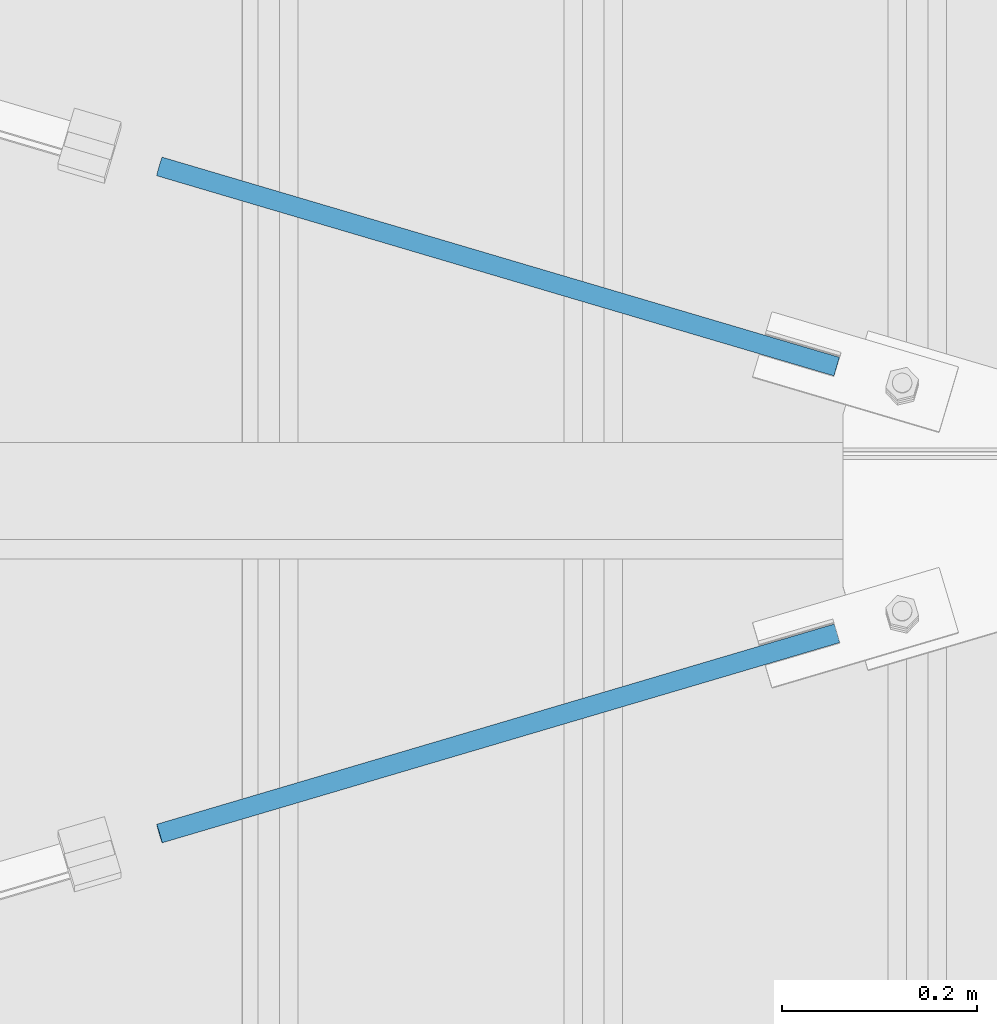
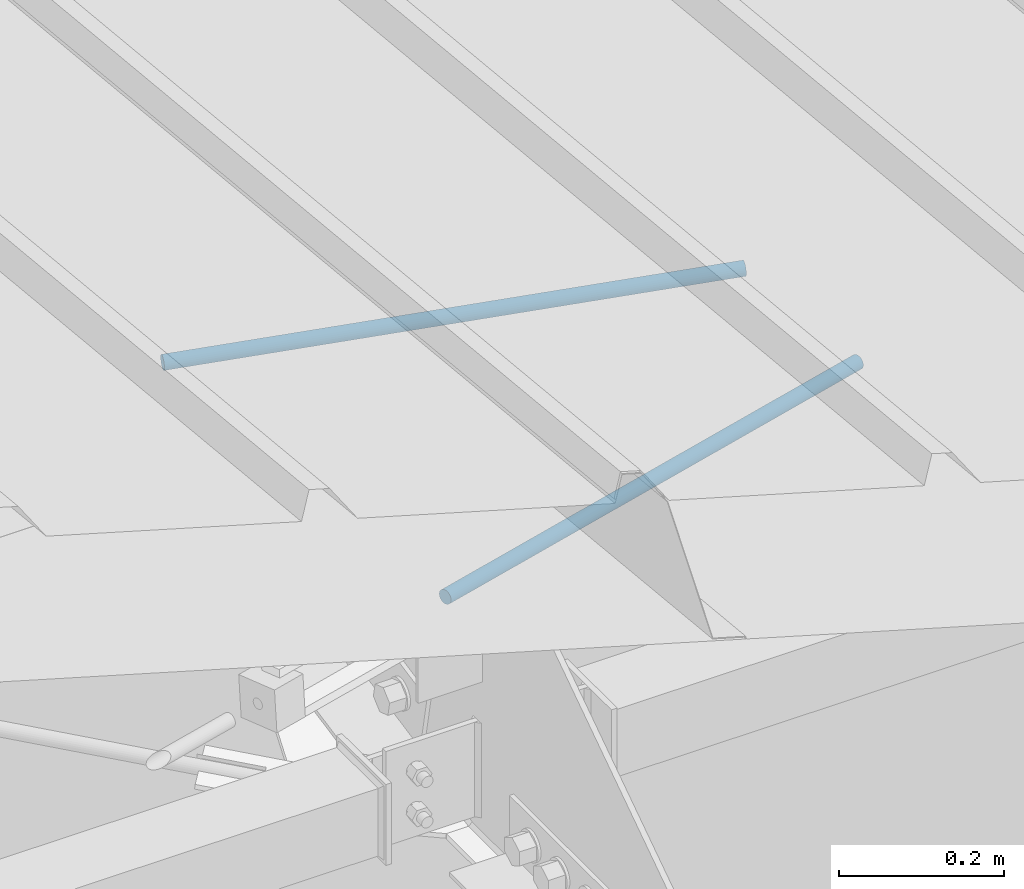
# One storey, part 297 of 709: 2 beams, 2 openings, 2 elements without a shape of their own.
"""IFC4 building model written with IfcOpenShell, lengths in millimetres."""

import ifcopenshell
import ifcopenshell.guid

model = None  # the IFC model being written
_history = None  # IfcOwnerHistory: only IFC2X3 demands one
_inside = {}  # id of a spatial element -> (the spatial element, [elements in it])
_under = {}  # id of a project, library or spatial element -> (it, [spatial elements below it])
_declared = {}  # id of a project -> (the project, [libraries it declares])
_typed = {}  # id of a type object -> (the type object, [elements of that type])
_made_of = {}  # id of a material, layer set ... -> (it, [elements and type objects made of it])


def new_model(schema):
    """Start an empty IFC model of exactly this schema.

    Asked for "IFC4X3", IfcOpenShell would pick the latest addendum, in which some entities
    have other attributes; the version numbers below select the first issue.
    IFC2X3 requires an IfcOwnerHistory on every rooted entity: one is made here for all.
    """
    global model, _history
    if schema == "IFC4X3":
        model = ifcopenshell.file(schema_version=(4, 3, 0, 0))
    else:
        model = ifcopenshell.file(schema=schema)
    _inside.clear()
    _under.clear()
    _declared.clear()
    _typed.clear()
    _made_of.clear()
    _history = None
    if model.schema == "IFC2X3":
        org = make("IfcOrganization", Name="unknown")
        user = make(
            "IfcPersonAndOrganization",
            ThePerson=make("IfcPerson", FamilyName="unknown"),
            TheOrganization=org,
        )
        app = make(
            "IfcApplication",
            ApplicationDeveloper=org,
            Version="unknown",
            ApplicationFullName="unknown",
            ApplicationIdentifier="unknown",
        )
        _history = make(
            "IfcOwnerHistory",
            OwningUser=user,
            OwningApplication=app,
            ChangeAction="ADDED",
            CreationDate=0,
        )
    return model


def make(cls, **values):
    """One entity of the class cls with the attributes given. An attribute that is None is left unset."""
    return model.create_entity(
        cls, **{name: value for name, value in values.items() if value is not None}
    )


def rooted(cls, **values):
    """An entity with a GlobalId (a new one), such as an element, a storey or a relation."""
    return make(cls, GlobalId=ifcopenshell.guid.new(), OwnerHistory=_history, **values)


def si_unit(unit_type, name, prefix=None):
    """IfcSIUnit, for example si_unit("LENGTHUNIT", "METRE", prefix="MILLI")."""
    return make("IfcSIUnit", UnitType=unit_type, Prefix=prefix, Name=name)


def assignment(units):
    """IfcUnitAssignment: the units of a project."""
    return None if units is None else make("IfcUnitAssignment", Units=units)


def point(xyz):
    """IfcCartesianPoint."""
    return None if xyz is None else make("IfcCartesianPoint", Coordinates=xyz)


def direction(xyz):
    """IfcDirection."""
    return None if xyz is None else make("IfcDirection", DirectionRatios=xyz)


def frame(location, z_axis=None, x_axis=None):
    """IfcAxis2Placement3D, a coordinate frame: its origin and axes. An axis left out is left unset."""
    return make(
        "IfcAxis2Placement3D",
        Location=point(location),
        Axis=direction(z_axis),
        RefDirection=direction(x_axis),
    )


def origin_with_axes():
    """The frame at (0, 0, 0) with the z axis (0, 0, 1) and the x axis (1, 0, 0) written out."""
    return frame((0.0, 0.0, 0.0), z_axis=(0.0, 0.0, 1.0), x_axis=(1.0, 0.0, 0.0))


def place(relative_to, where):
    """IfcLocalPlacement: puts the frame where relative to a parent placement (None: the world)."""
    return make(
        "IfcLocalPlacement", PlacementRelTo=relative_to, RelativePlacement=where
    )


def context(
    kind, dimensions, precision=None, world=None, true_north=None, identifier=None
):
    """IfcGeometricRepresentationContext, for example the 3D "Model" context."""
    return make(
        "IfcGeometricRepresentationContext",
        ContextIdentifier=identifier,
        ContextType=kind,
        CoordinateSpaceDimension=dimensions,
        Precision=precision,
        WorldCoordinateSystem=world,
        TrueNorth=true_north,
    )


def subcontext(parent, identifier, kind, view, scale=None):
    """IfcGeometricRepresentationSubContext, for example "Body" below "Model"."""
    return make(
        "IfcGeometricRepresentationSubContext",
        ContextIdentifier=identifier,
        ContextType=kind,
        ParentContext=parent,
        TargetScale=scale,
        TargetView=view,
    )


def project(units=None, contexts=None):
    """IfcProject with its units and contexts."""
    return rooted(
        "IfcProject",
        Name="project",
        RepresentationContexts=contexts,
        UnitsInContext=assignment(units),
    )


def spatial(cls, under=None, at=None, **own):
    """A site, building, storey or space (cls), placed at a placement, below another one or the project."""
    s = rooted(cls, ObjectPlacement=at, **own)
    if under is not None:
        _under.setdefault(under.id(), (under, []))[1].append(s)
    return s


def point_list(points):
    """IfcCartesianPointList2D or 3D."""
    cls = (
        "IfcCartesianPointList2D" if len(points[0]) == 2 else "IfcCartesianPointList3D"
    )
    return make(cls, CoordList=points)


def line(*indices):
    """IfcLineIndex: a straight run through numbered points of an indexed curve."""
    return model.create_entity("IfcLineIndex", indices)


def indexed_curve(points, segments=None, self_intersect=None):
    """IfcIndexedPolyCurve: lines and arcs through numbered points (the first is 1)."""
    return make(
        "IfcIndexedPolyCurve",
        Points=point_list(points),
        Segments=segments,
        SelfIntersect=self_intersect,
    )


def outline(outer, holes=None, kind="AREA"):
    """IfcArbitraryClosedProfileDef: a profile drawn as a closed curve; with holes, ...WithVoids."""
    if holes is None:
        return make("IfcArbitraryClosedProfileDef", ProfileType=kind, OuterCurve=outer)
    return make(
        "IfcArbitraryProfileDefWithVoids",
        ProfileType=kind,
        OuterCurve=outer,
        InnerCurves=holes,
    )


def extrude(swept, where, along, depth):
    """IfcExtrudedAreaSolid: the profile swept, set in the frame where, extruded along a direction by depth."""
    return make(
        "IfcExtrudedAreaSolid",
        SweptArea=swept,
        Position=where,
        ExtrudedDirection=direction(along),
        Depth=depth,
    )


def polygons(points, faces, closed=None, point_numbers=None):
    """IfcPolygonalFaceSet: a face is its outer loop, then its inner loops; points numbered from 1."""
    made = []
    for loops in faces:
        if len(loops) == 1:
            made.append(make("IfcIndexedPolygonalFace", CoordIndex=loops[0]))
        else:
            made.append(
                make(
                    "IfcIndexedPolygonalFaceWithVoids",
                    CoordIndex=loops[0],
                    InnerCoordIndices=loops[1:],
                )
            )
    return make(
        "IfcPolygonalFaceSet",
        Coordinates=point_list(points),
        Closed=closed,
        Faces=made,
        PnIndex=point_numbers,
    )


def shape(context_of_items, identifier, shape_type, items):
    """IfcShapeRepresentation: the items that make up one representation, for example the "Body"."""
    return make(
        "IfcShapeRepresentation",
        ContextOfItems=context_of_items,
        RepresentationIdentifier=identifier,
        RepresentationType=shape_type,
        Items=items,
    )


def material(Name=None, Category=None):
    """IfcMaterial."""
    return make("IfcMaterial", Name=Name, Category=Category)


def made_of(thing, what):
    """Note that an element or type object is made of a material, layer set ...; save() writes the relation."""
    if what is not None:
        _made_of.setdefault(what.id(), (what, []))[1].append(thing)
    return thing


def element(
    cls,
    number,
    at=None,
    inside=None,
    cuts=None,
    type_object=None,
    material=None,
    context=None,
    identifier="Body",
    shape_type=None,
    held_by="IfcProductDefinitionShape",
    body=None,
    shapes=None,
    **own,
):
    """One element of the class cls, such as IfcWall. Its Tag is "e" and its number.

    at: its placement. inside: the storey or other place that contains it. cuts: it is an
    opening in that element (IfcRelVoidsElement). A single representation is given by context,
    identifier, shape_type and body (its items); several are given by shapes. held_by: the class
    of the entity that holds the representations. save() writes the other relations.
    """
    e = rooted(cls, Tag="e%d" % number, ObjectPlacement=at, **own)
    if body is not None:
        shapes = [shape(context, identifier, shape_type, body)]
    if shapes is not None:
        e.Representation = make(held_by, Representations=shapes)
    if inside is not None:
        _inside.setdefault(inside.id(), (inside, []))[1].append(e)
    if cuts is not None:
        rooted(
            "IfcRelVoidsElement", RelatingBuildingElement=cuts, RelatedOpeningElement=e
        )
    if type_object is not None:
        _typed.setdefault(type_object.id(), (type_object, []))[1].append(e)
    return made_of(e, material)


def aggregate(whole, parts):
    """IfcRelAggregates: a whole, such as a stair, and the parts it consists of."""
    return rooted("IfcRelAggregates", RelatingObject=whole, RelatedObjects=parts)


def save(model, path):
    """Write the relations noted so far, then the file.

    IfcRelAggregates (storeys below a building ...), IfcRelContainedInSpatialStructure (elements
    in a storey), IfcRelDefinesByType, IfcRelAssociatesMaterial and IfcRelDeclares: one each for
    every whole, place, type object, material and project.
    """
    for whole, parts in _under.values():
        aggregate(whole, parts)
    for where, things in _inside.values():
        rooted(
            "IfcRelContainedInSpatialStructure",
            RelatedElements=things,
            RelatingStructure=where,
        )
    for kind, things in _typed.values():
        rooted("IfcRelDefinesByType", RelatedObjects=things, RelatingType=kind)
    for what, things in _made_of.values():
        rooted("IfcRelAssociatesMaterial", RelatedObjects=things, RelatingMaterial=what)
    for by, libraries in _declared.values():
        rooted("IfcRelDeclares", RelatingContext=by, RelatedDefinitions=libraries)
    model.write(path)


model = new_model("IFC4")

# Units and contexts
model_context = context("Model", 3, precision=0.2, world=origin_with_axes(), true_north=direction((0.0, 1.0)))
body_context = subcontext(model_context, "Body", "Model", "MODEL_VIEW")
reference_context = subcontext(model_context, "Reference", "Model", "MODEL_VIEW")
ifc_project = project(units=[si_unit("LENGTHUNIT", "METRE", prefix="MILLI"), si_unit("AREAUNIT", "SQUARE_METRE"), si_unit("VOLUMEUNIT", "CUBIC_METRE"), si_unit("MASSUNIT", "GRAM", prefix="KILO"), si_unit("TIMEUNIT", "SECOND"), si_unit("PLANEANGLEUNIT", "RADIAN"), si_unit("SOLIDANGLEUNIT", "STERADIAN"), si_unit("THERMODYNAMICTEMPERATUREUNIT", "DEGREE_CELSIUS"), si_unit("LUMINOUSINTENSITYUNIT", "LUMEN")], contexts=[model_context])

# Site, building, storey
site_placement = place(None, origin_with_axes())
site = spatial("IfcSite", under=ifc_project, at=site_placement, CompositionType="ELEMENT")
building_placement = place(site_placement, origin_with_axes())
building = spatial("IfcBuilding", under=site, at=building_placement, Name="Undefined", CompositionType="ELEMENT")
storey_placement = place(building_placement, origin_with_axes())
storey = spatial("IfcBuildingStorey", under=building, at=storey_placement, Name="Undefined", CompositionType="ELEMENT", Elevation=0.0)

# Assembly, beam, voiding feature
assembly_1_placement = place(storey_placement, frame((8657.949, 14340.80292, 7902.42372), z_axis=(0.2847296511, -0.9538504697, 0.095385047), x_axis=(0.9586078582, 0.2833165921, -0.028331659)))
assembly_1 = element("IfcElementAssembly", 1, at=assembly_1_placement, inside=storey)
ifc_material = material(Name="C355-5", Category="STEEL")
beam_1_placement = place(assembly_1_placement, origin_with_axes())
beam_1 = element("IfcBeam", 2, at=beam_1_placement, material=ifc_material, ObjectType="569", context=body_context, shape_type="Tessellation", body=[
    polygons([(916.31721, -5.0, 8.66025), (916.31721, -7.07107, 7.07107), (916.31721, -8.66025, 5.0), (916.31721, -9.65926, 2.58819), (916.31721, -10.0, 0.0), (916.31721, -9.65926, -2.58819), (916.31721, -8.66025, -5.0), (916.31721, -7.07107, -7.07107), (916.31721, -5.0, -8.66025), (916.31721, -2.58819, -9.65926), (916.31721, 0.0, -10.0), (916.31721, 2.58819, -9.65926), (916.31721, 5.0, -8.66025), (916.31721, 7.07107, -7.07107), (916.31721, 8.66025, -5.0), (916.31721, 9.65926, -2.58819), (916.31721, 10.0, 0.0), (916.31721, 9.65926, 2.58819), (916.31721, 8.66025, 5.0), (916.31721, 7.07107, 7.07107), (916.31721, 5.0, 8.66025), (916.31721, 2.58819, 9.65926), (916.31721, 0.0, 10.0), (916.31721, -2.58819, 9.65926), (190.0, 10.0, 0.0), (190.0, 9.65926, 2.58819), (190.0, 8.66025, 5.0), (190.0, 7.07107, 7.07107), (190.0, 5.0, 8.66025), (190.0, 2.58819, 9.65926), (190.0, 0.0, 10.0), (190.0, -2.58819, 9.65926), (190.0, -5.0, 8.66025), (190.0, -7.07107, 7.07107), (190.0, -8.66025, 5.0), (190.0, -9.65926, 2.58819), (190.0, -10.0, 0.0), (190.0, -9.65926, -2.58819), (190.0, -8.66025, -5.0), (190.0, -7.07107, -7.07107), (190.0, -5.0, -8.66025), (190.0, -2.58819, -9.65926), (190.0, 0.0, -10.0), (190.0, 2.58819, -9.65926), (190.0, 5.0, -8.66025), (190.0, 7.07107, -7.07107), (190.0, 8.66025, -5.0), (190.0, 9.65926, -2.58819), (10.0, 7.36122, 4.25), (190.0, 7.36122, 4.25), (190.0, 8.21037, 2.19996), (10.0, 8.21037, 2.19996), (10.0, 6.01041, 6.01041), (190.0, 6.01041, 6.01041), (10.0, 4.25, 7.36122), (190.0, 4.25, 7.36122), (10.0, 2.19996, 8.21037), (190.0, 2.19996, 8.21037), (10.0, 0.0, 8.5), (190.0, 0.0, 8.5), (10.0, -2.19996, 8.21037), (190.0, -2.19996, 8.21037), (10.0, -4.25, 7.36122), (190.0, -4.25, 7.36122), (10.0, -6.01041, 6.01041), (190.0, -6.01041, 6.01041), (10.0, -7.36122, 4.25), (190.0, -7.36122, 4.25), (10.0, -8.21037, 2.19996), (190.0, -8.21037, 2.19996), (10.0, -8.5, 0.0), (190.0, -8.5, 0.0), (10.0, -8.21037, -2.19996), (190.0, -8.21037, -2.19996), (10.0, -7.36122, -4.25), (190.0, -7.36122, -4.25), (10.0, -6.01041, -6.01041), (190.0, -6.01041, -6.01041), (10.0, -4.25, -7.36122), (190.0, -4.25, -7.36122), (10.0, -2.19996, -8.21037), (190.0, -2.19996, -8.21037), (10.0, 0.0, -8.5), (190.0, 0.0, -8.5), (10.0, 2.19996, -8.21037), (190.0, 2.19996, -8.21037), (10.0, 4.25, -7.36122), (190.0, 4.25, -7.36122), (10.0, 6.01041, -6.01041), (190.0, 6.01041, -6.01041), (10.0, 7.36122, -4.25), (190.0, 7.36122, -4.25), (10.0, 8.21037, -2.19996), (190.0, 8.21037, -2.19996), (10.0, 8.5, 0.0), (190.0, 8.5, 0.0)], [[[1, 2, 3, 4, 5, 6, 7, 8, 9, 10, 11, 12, 13, 14, 15, 16, 17, 18, 19, 20, 21, 22, 23, 24]], [[18, 17, 25, 26]], [[19, 18, 26, 27]], [[20, 19, 27, 28]], [[21, 20, 28, 29]], [[22, 21, 29, 30]], [[23, 22, 30, 31]], [[24, 23, 31, 32]], [[1, 24, 32, 33]], [[2, 1, 33, 34]], [[3, 2, 34, 35]], [[4, 3, 35, 36]], [[5, 4, 36, 37]], [[6, 5, 37, 38]], [[7, 6, 38, 39]], [[8, 7, 39, 40]], [[9, 8, 40, 41]], [[10, 9, 41, 42]], [[11, 10, 42, 43]], [[12, 11, 43, 44]], [[13, 12, 44, 45]], [[14, 13, 45, 46]], [[15, 14, 46, 47]], [[16, 15, 47, 48]], [[17, 16, 48, 25]], [[25, 48, 47, 46, 45, 44, 43, 42, 41, 40, 39, 38, 37, 36, 35, 34, 33, 32, 31, 30, 29, 28, 27, 26], [74, 76, 78, 80, 82, 84, 86, 88, 90, 92, 94, 96, 51, 50, 54, 56, 58, 60, 62, 64, 66, 68, 70, 72]], [[49, 50, 51, 52]], [[53, 54, 50, 49]], [[55, 56, 54, 53]], [[57, 58, 56, 55]], [[59, 60, 58, 57]], [[61, 62, 60, 59]], [[63, 64, 62, 61]], [[65, 66, 64, 63]], [[67, 68, 66, 65]], [[69, 70, 68, 67]], [[71, 72, 70, 69]], [[73, 74, 72, 71]], [[75, 76, 74, 73]], [[77, 78, 76, 75]], [[79, 80, 78, 77]], [[81, 82, 80, 79]], [[83, 84, 82, 81]], [[85, 86, 84, 83]], [[87, 88, 86, 85]], [[89, 90, 88, 87]], [[91, 92, 90, 89]], [[93, 94, 92, 91]], [[95, 96, 94, 93]], [[52, 51, 96, 95]], [[91, 89, 87, 85, 83, 81, 79, 77, 75, 73, 71, 69, 67, 65, 63, 61, 59, 57, 55, 53, 49, 52, 95, 93]]], closed=True),
])
voiding_feature_1_placement = place(beam_1_placement, frame((10.0, 0.0, 0.0), z_axis=(0.0, -1.0, 0.0), x_axis=(1.0, 0.0, 0.0)))
element("IfcVoidingFeature", 3, at=voiding_feature_1_placement, cuts=beam_1, PredefinedType="HOLE", context=reference_context, identifier="Reference", shape_type="SolidModel", body=[
    extrude(outline(indexed_curve([(10.5, 0.0), (10.14222, 2.7176), (9.09327, 5.25), (7.42462, 7.42462), (5.25, 9.09327), (2.7176, 10.14222), (0.0, 10.5), (-2.7176, 10.14222), (-5.25, 9.09327), (-7.42462, 7.42462), (-9.09327, 5.25), (-10.14222, 2.7176), (-10.5, 0.0), (-10.14222, -2.7176), (-9.09327, -5.25), (-7.42462, -7.42462), (-5.25, -9.09327), (-2.7176, -10.14222), (0.0, -10.5), (2.7176, -10.14222), (5.25, -9.09327), (7.42462, -7.42462), (9.09327, -5.25), (10.14222, -2.7176)], segments=[line(1, 2, 3, 4, 5, 6, 7, 8, 9, 10, 11, 12, 13, 14, 15, 16, 17, 18, 19, 20, 21, 22, 23, 24, 1)])), frame((0.0, 0.0, 0.0), z_axis=(-1.0, 0.0, 0.0), x_axis=(0.0, 0.0, 1.0)), (0.0, 0.0, -1.0), 180.0),
])
aggregate(assembly_1, [beam_1])

assembly_2_placement = place(storey_placement, frame((8657.949, 15134.08938, 7823.09508), z_axis=(-0.2847296511, -0.9538504697, 0.095385047), x_axis=(0.9586078582, -0.2833165921, 0.028331659)))
assembly_2 = element("IfcElementAssembly", 4, at=assembly_2_placement, inside=storey)
beam_2_placement = place(assembly_2_placement, origin_with_axes())
beam_2 = element("IfcBeam", 5, at=beam_2_placement, material=ifc_material, ObjectType="569", context=body_context, shape_type="Tessellation", body=[
    polygons([(916.31721, -5.0, 8.66025), (916.31721, -7.07107, 7.07107), (916.31721, -8.66025, 5.0), (916.31721, -9.65926, 2.58819), (916.31721, -10.0, 0.0), (916.31721, -9.65926, -2.58819), (916.31721, -8.66025, -5.0), (916.31721, -7.07107, -7.07107), (916.31721, -5.0, -8.66025), (916.31721, -2.58819, -9.65926), (916.31721, 0.0, -10.0), (916.31721, 2.58819, -9.65926), (916.31721, 5.0, -8.66025), (916.31721, 7.07107, -7.07107), (916.31721, 8.66025, -5.0), (916.31721, 9.65926, -2.58819), (916.31721, 10.0, 0.0), (916.31721, 9.65926, 2.58819), (916.31721, 8.66025, 5.0), (916.31721, 7.07107, 7.07107), (916.31721, 5.0, 8.66025), (916.31721, 2.58819, 9.65926), (916.31721, 0.0, 10.0), (916.31721, -2.58819, 9.65926), (190.0, 10.0, 0.0), (190.0, 9.65926, 2.58819), (190.0, 8.66025, 5.0), (190.0, 7.07107, 7.07107), (190.0, 5.0, 8.66025), (190.0, 2.58819, 9.65926), (190.0, 0.0, 10.0), (190.0, -2.58819, 9.65926), (190.0, -5.0, 8.66025), (190.0, -7.07107, 7.07107), (190.0, -8.66025, 5.0), (190.0, -9.65926, 2.58819), (190.0, -10.0, 0.0), (190.0, -9.65926, -2.58819), (190.0, -8.66025, -5.0), (190.0, -7.07107, -7.07107), (190.0, -5.0, -8.66025), (190.0, -2.58819, -9.65926), (190.0, 0.0, -10.0), (190.0, 2.58819, -9.65926), (190.0, 5.0, -8.66025), (190.0, 7.07107, -7.07107), (190.0, 8.66025, -5.0), (190.0, 9.65926, -2.58819), (10.0, 7.36122, 4.25), (190.0, 7.36122, 4.25), (190.0, 8.21037, 2.19996), (10.0, 8.21037, 2.19996), (10.0, 6.01041, 6.01041), (190.0, 6.01041, 6.01041), (10.0, 4.25, 7.36122), (190.0, 4.25, 7.36122), (10.0, 2.19996, 8.21037), (190.0, 2.19996, 8.21037), (10.0, 0.0, 8.5), (190.0, 0.0, 8.5), (10.0, -2.19996, 8.21037), (190.0, -2.19996, 8.21037), (10.0, -4.25, 7.36122), (190.0, -4.25, 7.36122), (10.0, -6.01041, 6.01041), (190.0, -6.01041, 6.01041), (10.0, -7.36122, 4.25), (190.0, -7.36122, 4.25), (10.0, -8.21037, 2.19996), (190.0, -8.21037, 2.19996), (10.0, -8.5, 0.0), (190.0, -8.5, 0.0), (10.0, -8.21037, -2.19996), (190.0, -8.21037, -2.19996), (10.0, -7.36122, -4.25), (190.0, -7.36122, -4.25), (10.0, -6.01041, -6.01041), (190.0, -6.01041, -6.01041), (10.0, -4.25, -7.36122), (190.0, -4.25, -7.36122), (10.0, -2.19996, -8.21037), (190.0, -2.19996, -8.21037), (10.0, 0.0, -8.5), (190.0, 0.0, -8.5), (10.0, 2.19996, -8.21037), (190.0, 2.19996, -8.21037), (10.0, 4.25, -7.36122), (190.0, 4.25, -7.36122), (10.0, 6.01041, -6.01041), (190.0, 6.01041, -6.01041), (10.0, 7.36122, -4.25), (190.0, 7.36122, -4.25), (10.0, 8.21037, -2.19996), (190.0, 8.21037, -2.19996), (10.0, 8.5, 0.0), (190.0, 8.5, 0.0)], [[[1, 2, 3, 4, 5, 6, 7, 8, 9, 10, 11, 12, 13, 14, 15, 16, 17, 18, 19, 20, 21, 22, 23, 24]], [[18, 17, 25, 26]], [[19, 18, 26, 27]], [[20, 19, 27, 28]], [[21, 20, 28, 29]], [[22, 21, 29, 30]], [[23, 22, 30, 31]], [[24, 23, 31, 32]], [[1, 24, 32, 33]], [[2, 1, 33, 34]], [[3, 2, 34, 35]], [[4, 3, 35, 36]], [[5, 4, 36, 37]], [[6, 5, 37, 38]], [[7, 6, 38, 39]], [[8, 7, 39, 40]], [[9, 8, 40, 41]], [[10, 9, 41, 42]], [[11, 10, 42, 43]], [[12, 11, 43, 44]], [[13, 12, 44, 45]], [[14, 13, 45, 46]], [[15, 14, 46, 47]], [[16, 15, 47, 48]], [[17, 16, 48, 25]], [[25, 48, 47, 46, 45, 44, 43, 42, 41, 40, 39, 38, 37, 36, 35, 34, 33, 32, 31, 30, 29, 28, 27, 26], [74, 76, 78, 80, 82, 84, 86, 88, 90, 92, 94, 96, 51, 50, 54, 56, 58, 60, 62, 64, 66, 68, 70, 72]], [[49, 50, 51, 52]], [[53, 54, 50, 49]], [[55, 56, 54, 53]], [[57, 58, 56, 55]], [[59, 60, 58, 57]], [[61, 62, 60, 59]], [[63, 64, 62, 61]], [[65, 66, 64, 63]], [[67, 68, 66, 65]], [[69, 70, 68, 67]], [[71, 72, 70, 69]], [[73, 74, 72, 71]], [[75, 76, 74, 73]], [[77, 78, 76, 75]], [[79, 80, 78, 77]], [[81, 82, 80, 79]], [[83, 84, 82, 81]], [[85, 86, 84, 83]], [[87, 88, 86, 85]], [[89, 90, 88, 87]], [[91, 92, 90, 89]], [[93, 94, 92, 91]], [[95, 96, 94, 93]], [[52, 51, 96, 95]], [[91, 89, 87, 85, 83, 81, 79, 77, 75, 73, 71, 69, 67, 65, 63, 61, 59, 57, 55, 53, 49, 52, 95, 93]]], closed=True),
])
voiding_feature_2_placement = place(beam_2_placement, frame((10.0, 0.0, 0.0), z_axis=(0.0, -1.0, 0.0), x_axis=(1.0, 0.0, 0.0)))
element("IfcVoidingFeature", 6, at=voiding_feature_2_placement, cuts=beam_2, PredefinedType="HOLE", context=reference_context, identifier="Reference", shape_type="SolidModel", body=[
    extrude(outline(indexed_curve([(10.5, 0.0), (10.14222, 2.7176), (9.09327, 5.25), (7.42462, 7.42462), (5.25, 9.09327), (2.7176, 10.14222), (0.0, 10.5), (-2.7176, 10.14222), (-5.25, 9.09327), (-7.42462, 7.42462), (-9.09327, 5.25), (-10.14222, 2.7176), (-10.5, 0.0), (-10.14222, -2.7176), (-9.09327, -5.25), (-7.42462, -7.42462), (-5.25, -9.09327), (-2.7176, -10.14222), (0.0, -10.5), (2.7176, -10.14222), (5.25, -9.09327), (7.42462, -7.42462), (9.09327, -5.25), (10.14222, -2.7176)], segments=[line(1, 2, 3, 4, 5, 6, 7, 8, 9, 10, 11, 12, 13, 14, 15, 16, 17, 18, 19, 20, 21, 22, 23, 24, 1)])), frame((0.0, 0.0, 0.0), z_axis=(-1.0, 0.0, 0.0), x_axis=(0.0, 0.0, 1.0)), (0.0, 0.0, -1.0), 180.0),
])
aggregate(assembly_2, [beam_2])

save(model, "model.ifc")
